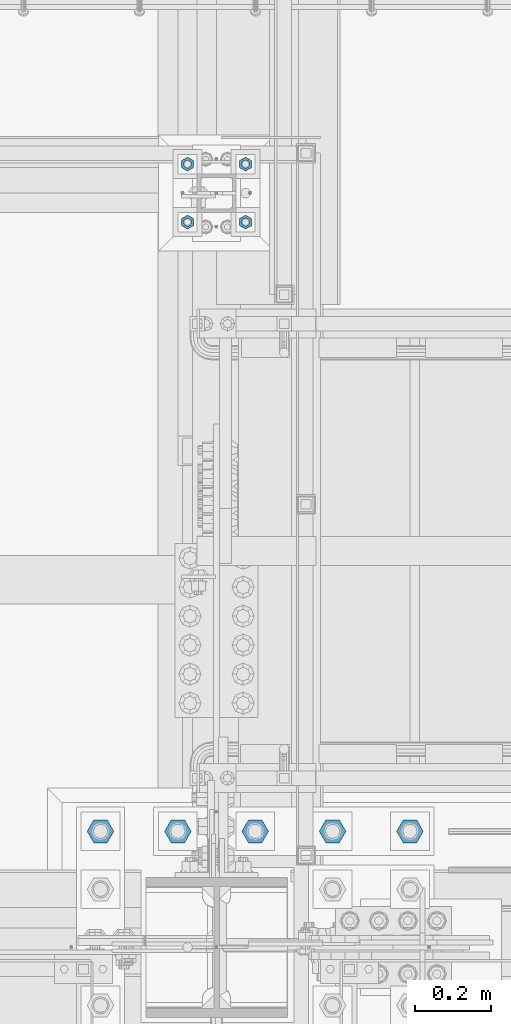
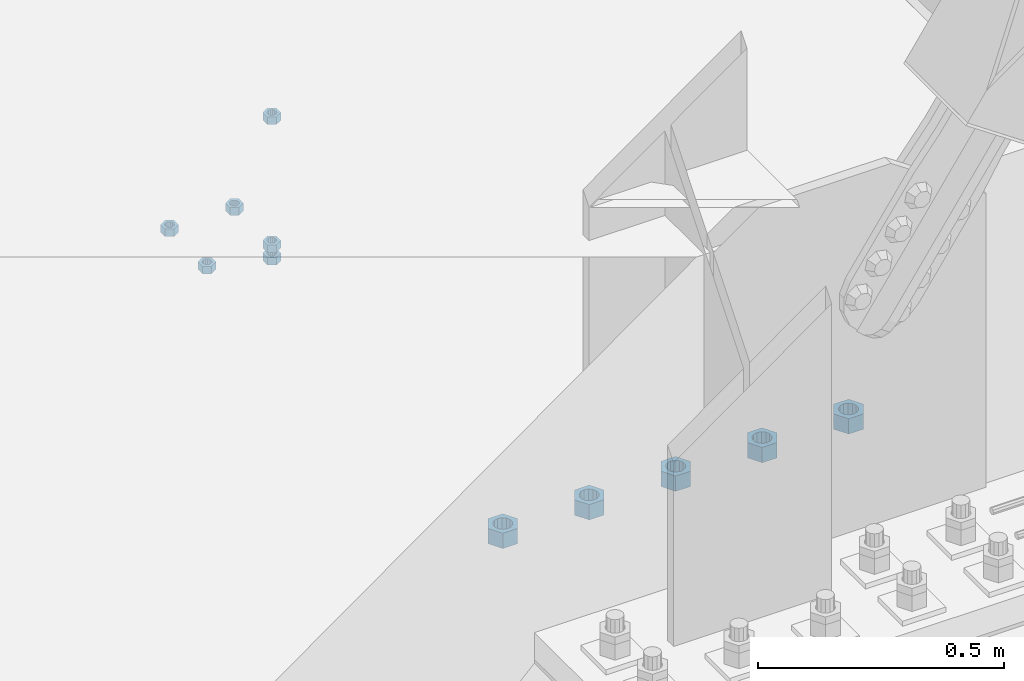
# One storey, part 1666 of 3843: 11 columns, 2 elements without a shape of their own.
"""IFC2X3 building model written with IfcOpenShell, lengths in millimetres."""

from ifc_helpers import new_model, si_unit, frame, origin_with_axes, place, context, subcontext, project, spatial, faceted_brep, material, type_object, element, aggregate, save


model = new_model("IFC2X3")

# Units and contexts
model_context = context("Model", 3, precision=1e-05, world=origin_with_axes())
body_context = subcontext(model_context, "Body", "Model", "MODEL_VIEW")
ifc_project = project(units=[si_unit("LENGTHUNIT", "METRE", prefix="MILLI"), si_unit("AREAUNIT", "SQUARE_METRE"), si_unit("VOLUMEUNIT", "CUBIC_METRE"), si_unit("MASSUNIT", "GRAM", prefix="KILO"), si_unit("TIMEUNIT", "SECOND"), si_unit("PLANEANGLEUNIT", "RADIAN"), si_unit("SOLIDANGLEUNIT", "STERADIAN"), si_unit("THERMODYNAMICTEMPERATUREUNIT", "DEGREE_CELSIUS"), si_unit("LUMINOUSINTENSITYUNIT", "LUMEN")], contexts=[model_context])

# Site, building, storey
site_placement = place(None, origin_with_axes())
site = spatial("IfcSite", under=ifc_project, at=site_placement, CompositionType="ELEMENT")
building_placement = place(site_placement, origin_with_axes())
building = spatial("IfcBuilding", under=site, at=building_placement, Name="Undefined", CompositionType="ELEMENT")
storey_placement = place(building_placement, origin_with_axes())
storey = spatial("IfcBuildingStorey", under=building, at=storey_placement, Name="Undefined", CompositionType="ELEMENT", Elevation=0.0)

# Assembly, columns
assembly_1_placement = place(storey_placement, origin_with_axes())
assembly_1 = element("IfcElementAssembly", 1, at=assembly_1_placement, inside=storey, Name="TEMPLATE", AssemblyPlace="NOTDEFINED", PredefinedType="RIGID_FRAME")
ifc_material_1 = material(Name="STEEL/A36")
column_type_1 = type_object("IfcColumnType", Name="3/4_HEAVY_HEX_NUT", PredefinedType="NOTDEFINED")
column_1_placement = place(assembly_1_placement, frame((56007.0, 27520.9, 29330.65), z_axis=(1.0, 0.0, 0.0), x_axis=(0.0, 0.0, -1.0)))
column_1 = element("IfcColumn", 2, at=column_1_placement, type_object=column_type_1, material=ifc_material_1, Name="NUT", ObjectType="3/4_HEAVY_HEX_NUT", context=body_context, shape_type="Brep", body=[
    faceted_brep([(0.0, -18.2600002288818, 0.0), (0.0, -9.13000011444092, -15.8100004196167), (19.0500000000029, -9.13000011444092, -15.8100004196167), (19.0500000000029, -18.2600002288818, 0.0), (0.0, 9.13000011444092, -15.8100004196167), (19.0500000000029, 9.13000011444092, -15.8100004196167), (0.0, 18.2600002288818, 0.0), (19.0500000000029, 18.2600002288818, 0.0), (0.0, 9.13000011444092, 15.8100004196167), (19.0500000000029, 9.13000011444092, 15.8100004196167), (0.0, -9.13000011444092, 15.8100004196167), (19.0500000000029, -9.13000011444092, 15.8100004196167), (0.0, 0.0, 10.3199996948242), (0.0, 4.47768005527905, 9.29799844179797), (19.0500000000029, 4.47768005527905, 9.29799844179797), (19.0500000000029, 0.0, 10.3199996948242), (0.0, 8.06850066047627, 6.43441456490837), (19.0500000000029, 8.06850066047627, 6.43441456490837), (0.0, 10.0612557561908, 2.2964159705225), (19.0500000000029, 10.0612557561908, 2.2964159705225), (0.0, 10.0612557561908, -2.2964159705225), (19.0500000000029, 10.0612557561908, -2.2964159705225), (0.0, 8.06850066047627, -6.43441456490837), (19.0500000000029, 8.06850066047627, -6.43441456490837), (0.0, 4.47768005527905, -9.29799844179797), (19.0500000000029, 4.47768005527905, -9.29799844179797), (0.0, 0.0, -10.3199996948242), (19.0500000000029, 0.0, -10.3199996948242), (0.0, -4.47768005527905, -9.29799844179797), (19.0500000000029, -4.47768005527905, -9.29799844179797), (0.0, -8.06850066047627, -6.43441456490837), (19.0500000000029, -8.06850066047627, -6.43441456490837), (0.0, -10.0612557561908, -2.2964159705225), (19.0500000000029, -10.0612557561908, -2.2964159705225), (0.0, -10.0612557561908, 2.2964159705225), (19.0500000000029, -10.0612557561908, 2.2964159705225), (0.0, -8.06850066047627, 6.43441456490837), (19.0500000000029, -8.06850066047627, 6.43441456490837), (0.0, -4.47768005527905, 9.29799844179797), (19.0500000000029, -4.47768005527905, 9.29799844179797)], [[[0, 1, 2, 3]], [[1, 4, 5, 2]], [[4, 6, 7, 5]], [[6, 8, 9, 7]], [[8, 10, 11, 9]], [[10, 0, 3, 11]], [[12, 13, 14, 15]], [[13, 16, 17, 14]], [[16, 18, 19, 17]], [[18, 20, 21, 19]], [[20, 22, 23, 21]], [[22, 24, 25, 23]], [[24, 26, 27, 25]], [[26, 28, 29, 27]], [[28, 30, 31, 29]], [[30, 32, 33, 31]], [[32, 34, 35, 33]], [[34, 36, 37, 35]], [[36, 38, 39, 37]], [[38, 12, 15, 39]], [[5, 7, 9, 11, 3, 2], [17, 19, 21, 23, 25, 27, 29, 31, 33, 35, 37, 39, 15, 14]], [[10, 8, 6, 4, 1, 0], [38, 36, 34, 32, 30, 28, 26, 24, 22, 20, 18, 16, 13, 12]]]),
])
column_2_placement = place(assembly_1_placement, frame((56007.0, 27673.3, 29330.65), z_axis=(-1.0, 0.0, 0.0), x_axis=(0.0, 0.0, -1.0)))
column_2 = element("IfcColumn", 3, at=column_2_placement, type_object=column_type_1, material=ifc_material_1, Name="NUT", ObjectType="3/4_HEAVY_HEX_NUT", context=body_context, shape_type="Brep", body=[
    faceted_brep([(0.0, -18.2600002288818, 0.0), (0.0, -9.13000011444092, -15.8100004196167), (19.0500000000029, -9.13000011444092, -15.8100004196167), (19.0500000000029, -18.2600002288818, 0.0), (0.0, 9.13000011444092, -15.8100004196167), (19.0500000000029, 9.13000011444092, -15.8100004196167), (0.0, 18.2600002288818, 0.0), (19.0500000000029, 18.2600002288818, 0.0), (0.0, 9.13000011444092, 15.8100004196167), (19.0500000000029, 9.13000011444092, 15.8100004196167), (0.0, -9.13000011444092, 15.8100004196167), (19.0500000000029, -9.13000011444092, 15.8100004196167), (0.0, 0.0, 10.3199996948242), (0.0, 4.47768005527905, 9.29799844179797), (19.0500000000029, 4.47768005527905, 9.29799844179797), (19.0500000000029, 0.0, 10.3199996948242), (0.0, 8.06850066047627, 6.43441456490837), (19.0500000000029, 8.06850066047627, 6.43441456490837), (0.0, 10.0612557561908, 2.2964159705225), (19.0500000000029, 10.0612557561908, 2.2964159705225), (0.0, 10.0612557561908, -2.2964159705225), (19.0500000000029, 10.0612557561908, -2.2964159705225), (0.0, 8.06850066047627, -6.43441456490837), (19.0500000000029, 8.06850066047627, -6.43441456490837), (0.0, 4.47768005527905, -9.29799844179797), (19.0500000000029, 4.47768005527905, -9.29799844179797), (0.0, 0.0, -10.3199996948242), (19.0500000000029, 0.0, -10.3199996948242), (0.0, -4.47768005527905, -9.29799844179797), (19.0500000000029, -4.47768005527905, -9.29799844179797), (0.0, -8.06850066047627, -6.43441456490837), (19.0500000000029, -8.06850066047627, -6.43441456490837), (0.0, -10.0612557561908, -2.2964159705225), (19.0500000000029, -10.0612557561908, -2.2964159705225), (0.0, -10.0612557561908, 2.2964159705225), (19.0500000000029, -10.0612557561908, 2.2964159705225), (0.0, -8.06850066047627, 6.43441456490837), (19.0500000000029, -8.06850066047627, 6.43441456490837), (0.0, -4.47768005527905, 9.29799844179797), (19.0500000000029, -4.47768005527905, 9.29799844179797)], [[[0, 1, 2, 3]], [[1, 4, 5, 2]], [[4, 6, 7, 5]], [[6, 8, 9, 7]], [[8, 10, 11, 9]], [[10, 0, 3, 11]], [[12, 13, 14, 15]], [[13, 16, 17, 14]], [[16, 18, 19, 17]], [[18, 20, 21, 19]], [[20, 22, 23, 21]], [[22, 24, 25, 23]], [[24, 26, 27, 25]], [[26, 28, 29, 27]], [[28, 30, 31, 29]], [[30, 32, 33, 31]], [[32, 34, 35, 33]], [[34, 36, 37, 35]], [[36, 38, 39, 37]], [[38, 12, 15, 39]], [[5, 7, 9, 11, 3, 2], [17, 19, 21, 23, 25, 27, 29, 31, 33, 35, 37, 39, 15, 14]], [[10, 8, 6, 4, 1, 0], [38, 36, 34, 32, 30, 28, 26, 24, 22, 20, 18, 16, 13, 12]]]),
])
column_3_placement = place(assembly_1_placement, frame((55854.6, 27520.9, 29330.65), z_axis=(1.0, 0.0, 0.0), x_axis=(0.0, 0.0, -1.0)))
column_3 = element("IfcColumn", 4, at=column_3_placement, type_object=column_type_1, material=ifc_material_1, Name="NUT", ObjectType="3/4_HEAVY_HEX_NUT", context=body_context, shape_type="Brep", body=[
    faceted_brep([(0.0, -18.2600002288818, 0.0), (0.0, -9.13000011444092, -15.8100004196167), (19.0500000000029, -9.13000011444092, -15.8100004196167), (19.0500000000029, -18.2600002288818, 0.0), (0.0, 9.13000011444092, -15.8100004196167), (19.0500000000029, 9.13000011444092, -15.8100004196167), (0.0, 18.2600002288818, 0.0), (19.0500000000029, 18.2600002288818, 0.0), (0.0, 9.13000011444092, 15.8100004196167), (19.0500000000029, 9.13000011444092, 15.8100004196167), (0.0, -9.13000011444092, 15.8100004196167), (19.0500000000029, -9.13000011444092, 15.8100004196167), (0.0, 0.0, 10.3199996948242), (0.0, 4.47768005527905, 9.29799844179797), (19.0500000000029, 4.47768005527905, 9.29799844179797), (19.0500000000029, 0.0, 10.3199996948242), (0.0, 8.06850066047627, 6.43441456490837), (19.0500000000029, 8.06850066047627, 6.43441456490837), (0.0, 10.0612557561908, 2.2964159705225), (19.0500000000029, 10.0612557561908, 2.2964159705225), (0.0, 10.0612557561908, -2.2964159705225), (19.0500000000029, 10.0612557561908, -2.2964159705225), (0.0, 8.06850066047627, -6.43441456490837), (19.0500000000029, 8.06850066047627, -6.43441456490837), (0.0, 4.47768005527905, -9.29799844179797), (19.0500000000029, 4.47768005527905, -9.29799844179797), (0.0, 0.0, -10.3199996948242), (19.0500000000029, 0.0, -10.3199996948242), (0.0, -4.47768005527905, -9.29799844179797), (19.0500000000029, -4.47768005527905, -9.29799844179797), (0.0, -8.06850066047627, -6.43441456490837), (19.0500000000029, -8.06850066047627, -6.43441456490837), (0.0, -10.0612557561908, -2.2964159705225), (19.0500000000029, -10.0612557561908, -2.2964159705225), (0.0, -10.0612557561908, 2.2964159705225), (19.0500000000029, -10.0612557561908, 2.2964159705225), (0.0, -8.06850066047627, 6.43441456490837), (19.0500000000029, -8.06850066047627, 6.43441456490837), (0.0, -4.47768005527905, 9.29799844179797), (19.0500000000029, -4.47768005527905, 9.29799844179797)], [[[0, 1, 2, 3]], [[1, 4, 5, 2]], [[4, 6, 7, 5]], [[6, 8, 9, 7]], [[8, 10, 11, 9]], [[10, 0, 3, 11]], [[12, 13, 14, 15]], [[13, 16, 17, 14]], [[16, 18, 19, 17]], [[18, 20, 21, 19]], [[20, 22, 23, 21]], [[22, 24, 25, 23]], [[24, 26, 27, 25]], [[26, 28, 29, 27]], [[28, 30, 31, 29]], [[30, 32, 33, 31]], [[32, 34, 35, 33]], [[34, 36, 37, 35]], [[36, 38, 39, 37]], [[38, 12, 15, 39]], [[5, 7, 9, 11, 3, 2], [17, 19, 21, 23, 25, 27, 29, 31, 33, 35, 37, 39, 15, 14]], [[10, 8, 6, 4, 1, 0], [38, 36, 34, 32, 30, 28, 26, 24, 22, 20, 18, 16, 13, 12]]]),
])
column_4_placement = place(assembly_1_placement, frame((55854.6, 27673.3, 29330.65), z_axis=(-1.0, 0.0, 0.0), x_axis=(0.0, 0.0, -1.0)))
column_4 = element("IfcColumn", 5, at=column_4_placement, type_object=column_type_1, material=ifc_material_1, Name="NUT", ObjectType="3/4_HEAVY_HEX_NUT", context=body_context, shape_type="Brep", body=[
    faceted_brep([(0.0, -18.2600002288818, 0.0), (0.0, -9.13000011444092, -15.8100004196167), (19.0500000000029, -9.13000011444092, -15.8100004196167), (19.0500000000029, -18.2600002288818, 0.0), (0.0, 9.13000011444092, -15.8100004196167), (19.0500000000029, 9.13000011444092, -15.8100004196167), (0.0, 18.2600002288818, 0.0), (19.0500000000029, 18.2600002288818, 0.0), (0.0, 9.13000011444092, 15.8100004196167), (19.0500000000029, 9.13000011444092, 15.8100004196167), (0.0, -9.13000011444092, 15.8100004196167), (19.0500000000029, -9.13000011444092, 15.8100004196167), (0.0, 0.0, 10.3199996948242), (0.0, 4.47768005527905, 9.29799844179797), (19.0500000000029, 4.47768005527905, 9.29799844179797), (19.0500000000029, 0.0, 10.3199996948242), (0.0, 8.06850066047627, 6.43441456490837), (19.0500000000029, 8.06850066047627, 6.43441456490837), (0.0, 10.0612557561908, 2.2964159705225), (19.0500000000029, 10.0612557561908, 2.2964159705225), (0.0, 10.0612557561908, -2.2964159705225), (19.0500000000029, 10.0612557561908, -2.2964159705225), (0.0, 8.06850066047627, -6.43441456490837), (19.0500000000029, 8.06850066047627, -6.43441456490837), (0.0, 4.47768005527905, -9.29799844179797), (19.0500000000029, 4.47768005527905, -9.29799844179797), (0.0, 0.0, -10.3199996948242), (19.0500000000029, 0.0, -10.3199996948242), (0.0, -4.47768005527905, -9.29799844179797), (19.0500000000029, -4.47768005527905, -9.29799844179797), (0.0, -8.06850066047627, -6.43441456490837), (19.0500000000029, -8.06850066047627, -6.43441456490837), (0.0, -10.0612557561908, -2.2964159705225), (19.0500000000029, -10.0612557561908, -2.2964159705225), (0.0, -10.0612557561908, 2.2964159705225), (19.0500000000029, -10.0612557561908, 2.2964159705225), (0.0, -8.06850066047627, 6.43441456490837), (19.0500000000029, -8.06850066047627, 6.43441456490837), (0.0, -4.47768005527905, 9.29799844179797), (19.0500000000029, -4.47768005527905, 9.29799844179797)], [[[0, 1, 2, 3]], [[1, 4, 5, 2]], [[4, 6, 7, 5]], [[6, 8, 9, 7]], [[8, 10, 11, 9]], [[10, 0, 3, 11]], [[12, 13, 14, 15]], [[13, 16, 17, 14]], [[16, 18, 19, 17]], [[18, 20, 21, 19]], [[20, 22, 23, 21]], [[22, 24, 25, 23]], [[24, 26, 27, 25]], [[26, 28, 29, 27]], [[28, 30, 31, 29]], [[30, 32, 33, 31]], [[32, 34, 35, 33]], [[34, 36, 37, 35]], [[36, 38, 39, 37]], [[38, 12, 15, 39]], [[5, 7, 9, 11, 3, 2], [17, 19, 21, 23, 25, 27, 29, 31, 33, 35, 37, 39, 15, 14]], [[10, 8, 6, 4, 1, 0], [38, 36, 34, 32, 30, 28, 26, 24, 22, 20, 18, 16, 13, 12]]]),
])
column_5_placement = place(assembly_1_placement, frame((56007.0, 27520.9, 29648.15), z_axis=(1.0, 0.0, 0.0), x_axis=(0.0, 0.0, -1.0)))
column_5 = element("IfcColumn", 6, at=column_5_placement, type_object=column_type_1, material=ifc_material_1, Name="NUT", ObjectType="3/4_HEAVY_HEX_NUT", context=body_context, shape_type="Brep", body=[
    faceted_brep([(0.0, -18.2600002288818, 0.0), (0.0, -9.13000011444092, -15.8100004196167), (19.0500000000029, -9.13000011444092, -15.8100004196167), (19.0500000000029, -18.2600002288818, 0.0), (0.0, 9.13000011444092, -15.8100004196167), (19.0500000000029, 9.13000011444092, -15.8100004196167), (0.0, 18.2600002288818, 0.0), (19.0500000000029, 18.2600002288818, 0.0), (0.0, 9.13000011444092, 15.8100004196167), (19.0500000000029, 9.13000011444092, 15.8100004196167), (0.0, -9.13000011444092, 15.8100004196167), (19.0500000000029, -9.13000011444092, 15.8100004196167), (0.0, 0.0, 10.3199996948242), (0.0, 4.47768005527905, 9.29799844179797), (19.0500000000029, 4.47768005527905, 9.29799844179797), (19.0500000000029, 0.0, 10.3199996948242), (0.0, 8.06850066047627, 6.43441456490837), (19.0500000000029, 8.06850066047627, 6.43441456490837), (0.0, 10.0612557561908, 2.2964159705225), (19.0500000000029, 10.0612557561908, 2.2964159705225), (0.0, 10.0612557561908, -2.2964159705225), (19.0500000000029, 10.0612557561908, -2.2964159705225), (0.0, 8.06850066047627, -6.43441456490837), (19.0500000000029, 8.06850066047627, -6.43441456490837), (0.0, 4.47768005527905, -9.29799844179797), (19.0500000000029, 4.47768005527905, -9.29799844179797), (0.0, 0.0, -10.3199996948242), (19.0500000000029, 0.0, -10.3199996948242), (0.0, -4.47768005527905, -9.29799844179797), (19.0500000000029, -4.47768005527905, -9.29799844179797), (0.0, -8.06850066047627, -6.43441456490837), (19.0500000000029, -8.06850066047627, -6.43441456490837), (0.0, -10.0612557561908, -2.2964159705225), (19.0500000000029, -10.0612557561908, -2.2964159705225), (0.0, -10.0612557561908, 2.2964159705225), (19.0500000000029, -10.0612557561908, 2.2964159705225), (0.0, -8.06850066047627, 6.43441456490837), (19.0500000000029, -8.06850066047627, 6.43441456490837), (0.0, -4.47768005527905, 9.29799844179797), (19.0500000000029, -4.47768005527905, 9.29799844179797)], [[[0, 1, 2, 3]], [[1, 4, 5, 2]], [[4, 6, 7, 5]], [[6, 8, 9, 7]], [[8, 10, 11, 9]], [[10, 0, 3, 11]], [[12, 13, 14, 15]], [[13, 16, 17, 14]], [[16, 18, 19, 17]], [[18, 20, 21, 19]], [[20, 22, 23, 21]], [[22, 24, 25, 23]], [[24, 26, 27, 25]], [[26, 28, 29, 27]], [[28, 30, 31, 29]], [[30, 32, 33, 31]], [[32, 34, 35, 33]], [[34, 36, 37, 35]], [[36, 38, 39, 37]], [[38, 12, 15, 39]], [[5, 7, 9, 11, 3, 2], [17, 19, 21, 23, 25, 27, 29, 31, 33, 35, 37, 39, 15, 14]], [[10, 8, 6, 4, 1, 0], [38, 36, 34, 32, 30, 28, 26, 24, 22, 20, 18, 16, 13, 12]]]),
])
column_6_placement = place(assembly_1_placement, frame((56007.0, 27520.9, 29298.9), z_axis=(1.0, 0.0, 0.0), x_axis=(0.0, 0.0, -1.0)))
column_6 = element("IfcColumn", 7, at=column_6_placement, type_object=column_type_1, material=ifc_material_1, Name="NUT", ObjectType="3/4_HEAVY_HEX_NUT", context=body_context, shape_type="Brep", body=[
    faceted_brep([(0.0, -18.2600002288818, 0.0), (0.0, -9.13000011444092, -15.8100004196167), (19.0500000000029, -9.13000011444092, -15.8100004196167), (19.0500000000029, -18.2600002288818, 0.0), (0.0, 9.13000011444092, -15.8100004196167), (19.0500000000029, 9.13000011444092, -15.8100004196167), (0.0, 18.2600002288818, 0.0), (19.0500000000029, 18.2600002288818, 0.0), (0.0, 9.13000011444092, 15.8100004196167), (19.0500000000029, 9.13000011444092, 15.8100004196167), (0.0, -9.13000011444092, 15.8100004196167), (19.0500000000029, -9.13000011444092, 15.8100004196167), (0.0, 0.0, 10.3199996948242), (0.0, 4.47768005527905, 9.29799844179797), (19.0500000000029, 4.47768005527905, 9.29799844179797), (19.0500000000029, 0.0, 10.3199996948242), (0.0, 8.06850066047627, 6.43441456490837), (19.0500000000029, 8.06850066047627, 6.43441456490837), (0.0, 10.0612557561908, 2.2964159705225), (19.0500000000029, 10.0612557561908, 2.2964159705225), (0.0, 10.0612557561908, -2.2964159705225), (19.0500000000029, 10.0612557561908, -2.2964159705225), (0.0, 8.06850066047627, -6.43441456490837), (19.0500000000029, 8.06850066047627, -6.43441456490837), (0.0, 4.47768005527905, -9.29799844179797), (19.0500000000029, 4.47768005527905, -9.29799844179797), (0.0, 0.0, -10.3199996948242), (19.0500000000029, 0.0, -10.3199996948242), (0.0, -4.47768005527905, -9.29799844179797), (19.0500000000029, -4.47768005527905, -9.29799844179797), (0.0, -8.06850066047627, -6.43441456490837), (19.0500000000029, -8.06850066047627, -6.43441456490837), (0.0, -10.0612557561908, -2.2964159705225), (19.0500000000029, -10.0612557561908, -2.2964159705225), (0.0, -10.0612557561908, 2.2964159705225), (19.0500000000029, -10.0612557561908, 2.2964159705225), (0.0, -8.06850066047627, 6.43441456490837), (19.0500000000029, -8.06850066047627, 6.43441456490837), (0.0, -4.47768005527905, 9.29799844179797), (19.0500000000029, -4.47768005527905, 9.29799844179797)], [[[0, 1, 2, 3]], [[1, 4, 5, 2]], [[4, 6, 7, 5]], [[6, 8, 9, 7]], [[8, 10, 11, 9]], [[10, 0, 3, 11]], [[12, 13, 14, 15]], [[13, 16, 17, 14]], [[16, 18, 19, 17]], [[18, 20, 21, 19]], [[20, 22, 23, 21]], [[22, 24, 25, 23]], [[24, 26, 27, 25]], [[26, 28, 29, 27]], [[28, 30, 31, 29]], [[30, 32, 33, 31]], [[32, 34, 35, 33]], [[34, 36, 37, 35]], [[36, 38, 39, 37]], [[38, 12, 15, 39]], [[5, 7, 9, 11, 3, 2], [17, 19, 21, 23, 25, 27, 29, 31, 33, 35, 37, 39, 15, 14]], [[10, 8, 6, 4, 1, 0], [38, 36, 34, 32, 30, 28, 26, 24, 22, 20, 18, 16, 13, 12]]]),
])
aggregate(assembly_1, [column_1, column_2, column_3, column_4, column_5, column_6])

assembly_2_placement = place(storey_placement, origin_with_axes())
assembly_2 = element("IfcElementAssembly", 8, at=assembly_2_placement, inside=storey, Name="TEMPLATE", AssemblyPlace="NOTDEFINED", PredefinedType="RIGID_FRAME")
ifc_material_2 = material(Name="STEEL/A572-50")
column_type_2 = type_object("IfcColumnType", Name="1-1/2_HEAVY_HEX_NUT", PredefinedType="NOTDEFINED")
column_7_placement = place(assembly_2_placement, frame((55626.0, 25920.7, 29730.7), z_axis=(0.0, -1.0, 0.0), x_axis=(0.0, 0.0, -1.0)))
column_7 = element("IfcColumn", 9, at=column_7_placement, type_object=column_type_2, material=ifc_material_2, Name="NUT", ObjectType="1-1/2_HEAVY_HEX_NUT", context=body_context, shape_type="Brep", body=[
    faceted_brep([(0.0, -34.9199981689453, 0.0), (0.0, -17.4599990844727, -30.25), (38.0999999999985, -17.4599990844727, -30.25), (38.0999999999985, -34.9199981689453, 0.0), (0.0, 17.4599990844727, -30.25), (38.0999999999985, 17.4599990844727, -30.25), (0.0, 34.9199981689453, 0.0), (38.0999999999985, 34.9199981689453, 0.0), (0.0, 17.4599990844727, 30.25), (38.0999999999985, 17.4599990844727, 30.25), (0.0, -17.4599990844727, 30.25), (38.0999999999985, -17.4599990844727, 30.25), (0.0, 0.0, 20.6399993896484), (0.0, 8.9553601105581, 18.5959968835959), (38.0999999999985, 8.9553601105581, 18.5959968835959), (38.0999999999985, 0.0, 20.6399993896484), (0.0, 16.1370013209525, 12.8688291298167), (38.0999999999985, 16.1370013209525, 12.8688291298167), (0.0, 20.1225115123816, 4.59283194104501), (38.0999999999985, 20.1225115123816, 4.59283194104501), (0.0, 20.1225115123816, -4.59283194104501), (38.0999999999985, 20.1225115123816, -4.59283194104501), (0.0, 16.1370013209525, -12.8688291298167), (38.0999999999985, 16.1370013209525, -12.8688291298167), (0.0, 8.9553601105581, -18.5959968835959), (38.0999999999985, 8.9553601105581, -18.5959968835959), (0.0, 0.0, -20.6399993896484), (38.0999999999985, 0.0, -20.6399993896484), (0.0, -8.9553601105581, -18.5959968835959), (38.0999999999985, -8.9553601105581, -18.5959968835959), (0.0, -16.1370013209525, -12.8688291298167), (38.0999999999985, -16.1370013209525, -12.8688291298167), (0.0, -20.1225115123816, -4.59283194104501), (38.0999999999985, -20.1225115123816, -4.59283194104501), (0.0, -20.1225115123816, 4.59283194104501), (38.0999999999985, -20.1225115123816, 4.59283194104501), (0.0, -16.1370013209525, 12.8688291298167), (38.0999999999985, -16.1370013209525, 12.8688291298167), (0.0, -8.9553601105581, 18.5959968835959), (38.0999999999985, -8.9553601105581, 18.5959968835959)], [[[0, 1, 2, 3]], [[1, 4, 5, 2]], [[4, 6, 7, 5]], [[6, 8, 9, 7]], [[8, 10, 11, 9]], [[10, 0, 3, 11]], [[12, 13, 14, 15]], [[13, 16, 17, 14]], [[16, 18, 19, 17]], [[18, 20, 21, 19]], [[20, 22, 23, 21]], [[22, 24, 25, 23]], [[24, 26, 27, 25]], [[26, 28, 29, 27]], [[28, 30, 31, 29]], [[30, 32, 33, 31]], [[32, 34, 35, 33]], [[34, 36, 37, 35]], [[36, 38, 39, 37]], [[38, 12, 15, 39]], [[5, 7, 9, 11, 3, 2], [17, 19, 21, 23, 25, 27, 29, 31, 33, 35, 37, 39, 15, 14]], [[10, 8, 6, 4, 1, 0], [38, 36, 34, 32, 30, 28, 26, 24, 22, 20, 18, 16, 13, 12]]]),
])
column_8_placement = place(assembly_2_placement, frame((55829.2, 25920.7, 29730.7), z_axis=(0.0, -1.0, 0.0), x_axis=(0.0, 0.0, -1.0)))
column_8 = element("IfcColumn", 10, at=column_8_placement, type_object=column_type_2, material=ifc_material_2, Name="NUT", ObjectType="1-1/2_HEAVY_HEX_NUT", context=body_context, shape_type="Brep", body=[
    faceted_brep([(0.0, -34.9199981689453, 0.0), (0.0, -17.4599990844727, -30.25), (38.0999999999985, -17.4599990844727, -30.25), (38.0999999999985, -34.9199981689453, 0.0), (0.0, 17.4599990844727, -30.25), (38.0999999999985, 17.4599990844727, -30.25), (0.0, 34.9199981689453, 0.0), (38.0999999999985, 34.9199981689453, 0.0), (0.0, 17.4599990844727, 30.25), (38.0999999999985, 17.4599990844727, 30.25), (0.0, -17.4599990844727, 30.25), (38.0999999999985, -17.4599990844727, 30.25), (0.0, 0.0, 20.6399993896484), (0.0, 8.9553601105581, 18.5959968835959), (38.0999999999985, 8.9553601105581, 18.5959968835959), (38.0999999999985, 0.0, 20.6399993896484), (0.0, 16.1370013209525, 12.8688291298167), (38.0999999999985, 16.1370013209525, 12.8688291298167), (0.0, 20.1225115123816, 4.59283194104501), (38.0999999999985, 20.1225115123816, 4.59283194104501), (0.0, 20.1225115123816, -4.59283194104501), (38.0999999999985, 20.1225115123816, -4.59283194104501), (0.0, 16.1370013209525, -12.8688291298167), (38.0999999999985, 16.1370013209525, -12.8688291298167), (0.0, 8.9553601105581, -18.5959968835959), (38.0999999999985, 8.9553601105581, -18.5959968835959), (0.0, 0.0, -20.6399993896484), (38.0999999999985, 0.0, -20.6399993896484), (0.0, -8.9553601105581, -18.5959968835959), (38.0999999999985, -8.9553601105581, -18.5959968835959), (0.0, -16.1370013209525, -12.8688291298167), (38.0999999999985, -16.1370013209525, -12.8688291298167), (0.0, -20.1225115123816, -4.59283194104501), (38.0999999999985, -20.1225115123816, -4.59283194104501), (0.0, -20.1225115123816, 4.59283194104501), (38.0999999999985, -20.1225115123816, 4.59283194104501), (0.0, -16.1370013209525, 12.8688291298167), (38.0999999999985, -16.1370013209525, 12.8688291298167), (0.0, -8.9553601105581, 18.5959968835959), (38.0999999999985, -8.9553601105581, 18.5959968835959)], [[[0, 1, 2, 3]], [[1, 4, 5, 2]], [[4, 6, 7, 5]], [[6, 8, 9, 7]], [[8, 10, 11, 9]], [[10, 0, 3, 11]], [[12, 13, 14, 15]], [[13, 16, 17, 14]], [[16, 18, 19, 17]], [[18, 20, 21, 19]], [[20, 22, 23, 21]], [[22, 24, 25, 23]], [[24, 26, 27, 25]], [[26, 28, 29, 27]], [[28, 30, 31, 29]], [[30, 32, 33, 31]], [[32, 34, 35, 33]], [[34, 36, 37, 35]], [[36, 38, 39, 37]], [[38, 12, 15, 39]], [[5, 7, 9, 11, 3, 2], [17, 19, 21, 23, 25, 27, 29, 31, 33, 35, 37, 39, 15, 14]], [[10, 8, 6, 4, 1, 0], [38, 36, 34, 32, 30, 28, 26, 24, 22, 20, 18, 16, 13, 12]]]),
])
column_9_placement = place(assembly_2_placement, frame((56032.4, 25920.7, 29730.7), z_axis=(0.0, -1.0, 0.0), x_axis=(0.0, 0.0, -1.0)))
column_9 = element("IfcColumn", 11, at=column_9_placement, type_object=column_type_2, material=ifc_material_2, Name="NUT", ObjectType="1-1/2_HEAVY_HEX_NUT", context=body_context, shape_type="Brep", body=[
    faceted_brep([(0.0, -34.9199981689453, 0.0), (0.0, -17.4599990844727, -30.25), (38.0999999999985, -17.4599990844727, -30.25), (38.0999999999985, -34.9199981689453, 0.0), (0.0, 17.4599990844727, -30.25), (38.0999999999985, 17.4599990844727, -30.25), (0.0, 34.9199981689453, 0.0), (38.0999999999985, 34.9199981689453, 0.0), (0.0, 17.4599990844727, 30.25), (38.0999999999985, 17.4599990844727, 30.25), (0.0, -17.4599990844727, 30.25), (38.0999999999985, -17.4599990844727, 30.25), (0.0, 0.0, 20.6399993896484), (0.0, 8.9553601105581, 18.5959968835959), (38.0999999999985, 8.9553601105581, 18.5959968835959), (38.0999999999985, 0.0, 20.6399993896484), (0.0, 16.1370013209525, 12.8688291298167), (38.0999999999985, 16.1370013209525, 12.8688291298167), (0.0, 20.1225115123816, 4.59283194104501), (38.0999999999985, 20.1225115123816, 4.59283194104501), (0.0, 20.1225115123816, -4.59283194104501), (38.0999999999985, 20.1225115123816, -4.59283194104501), (0.0, 16.1370013209525, -12.8688291298167), (38.0999999999985, 16.1370013209525, -12.8688291298167), (0.0, 8.9553601105581, -18.5959968835959), (38.0999999999985, 8.9553601105581, -18.5959968835959), (0.0, 0.0, -20.6399993896484), (38.0999999999985, 0.0, -20.6399993896484), (0.0, -8.9553601105581, -18.5959968835959), (38.0999999999985, -8.9553601105581, -18.5959968835959), (0.0, -16.1370013209525, -12.8688291298167), (38.0999999999985, -16.1370013209525, -12.8688291298167), (0.0, -20.1225115123816, -4.59283194104501), (38.0999999999985, -20.1225115123816, -4.59283194104501), (0.0, -20.1225115123816, 4.59283194104501), (38.0999999999985, -20.1225115123816, 4.59283194104501), (0.0, -16.1370013209525, 12.8688291298167), (38.0999999999985, -16.1370013209525, 12.8688291298167), (0.0, -8.9553601105581, 18.5959968835959), (38.0999999999985, -8.9553601105581, 18.5959968835959)], [[[0, 1, 2, 3]], [[1, 4, 5, 2]], [[4, 6, 7, 5]], [[6, 8, 9, 7]], [[8, 10, 11, 9]], [[10, 0, 3, 11]], [[12, 13, 14, 15]], [[13, 16, 17, 14]], [[16, 18, 19, 17]], [[18, 20, 21, 19]], [[20, 22, 23, 21]], [[22, 24, 25, 23]], [[24, 26, 27, 25]], [[26, 28, 29, 27]], [[28, 30, 31, 29]], [[30, 32, 33, 31]], [[32, 34, 35, 33]], [[34, 36, 37, 35]], [[36, 38, 39, 37]], [[38, 12, 15, 39]], [[5, 7, 9, 11, 3, 2], [17, 19, 21, 23, 25, 27, 29, 31, 33, 35, 37, 39, 15, 14]], [[10, 8, 6, 4, 1, 0], [38, 36, 34, 32, 30, 28, 26, 24, 22, 20, 18, 16, 13, 12]]]),
])
column_10_placement = place(assembly_2_placement, frame((56235.6, 25920.7, 29730.7), z_axis=(0.0, 1.0, 0.0), x_axis=(0.0, 0.0, -1.0)))
column_10 = element("IfcColumn", 12, at=column_10_placement, type_object=column_type_2, material=ifc_material_2, Name="NUT", ObjectType="1-1/2_HEAVY_HEX_NUT", context=body_context, shape_type="Brep", body=[
    faceted_brep([(0.0, -34.9199981689453, 0.0), (0.0, -17.4599990844727, -30.25), (38.0999999999985, -17.4599990844727, -30.25), (38.0999999999985, -34.9199981689453, 0.0), (0.0, 17.4599990844727, -30.25), (38.0999999999985, 17.4599990844727, -30.25), (0.0, 34.9199981689453, 0.0), (38.0999999999985, 34.9199981689453, 0.0), (0.0, 17.4599990844727, 30.25), (38.0999999999985, 17.4599990844727, 30.25), (0.0, -17.4599990844727, 30.25), (38.0999999999985, -17.4599990844727, 30.25), (0.0, 0.0, 20.6399993896484), (0.0, 8.9553601105581, 18.5959968835959), (38.0999999999985, 8.9553601105581, 18.5959968835959), (38.0999999999985, 0.0, 20.6399993896484), (0.0, 16.1370013209525, 12.8688291298167), (38.0999999999985, 16.1370013209525, 12.8688291298167), (0.0, 20.1225115123816, 4.59283194104501), (38.0999999999985, 20.1225115123816, 4.59283194104501), (0.0, 20.1225115123816, -4.59283194104501), (38.0999999999985, 20.1225115123816, -4.59283194104501), (0.0, 16.1370013209525, -12.8688291298167), (38.0999999999985, 16.1370013209525, -12.8688291298167), (0.0, 8.9553601105581, -18.5959968835959), (38.0999999999985, 8.9553601105581, -18.5959968835959), (0.0, 0.0, -20.6399993896484), (38.0999999999985, 0.0, -20.6399993896484), (0.0, -8.9553601105581, -18.5959968835959), (38.0999999999985, -8.9553601105581, -18.5959968835959), (0.0, -16.1370013209525, -12.8688291298167), (38.0999999999985, -16.1370013209525, -12.8688291298167), (0.0, -20.1225115123816, -4.59283194104501), (38.0999999999985, -20.1225115123816, -4.59283194104501), (0.0, -20.1225115123816, 4.59283194104501), (38.0999999999985, -20.1225115123816, 4.59283194104501), (0.0, -16.1370013209525, 12.8688291298167), (38.0999999999985, -16.1370013209525, 12.8688291298167), (0.0, -8.9553601105581, 18.5959968835959), (38.0999999999985, -8.9553601105581, 18.5959968835959)], [[[0, 1, 2, 3]], [[1, 4, 5, 2]], [[4, 6, 7, 5]], [[6, 8, 9, 7]], [[8, 10, 11, 9]], [[10, 0, 3, 11]], [[12, 13, 14, 15]], [[13, 16, 17, 14]], [[16, 18, 19, 17]], [[18, 20, 21, 19]], [[20, 22, 23, 21]], [[22, 24, 25, 23]], [[24, 26, 27, 25]], [[26, 28, 29, 27]], [[28, 30, 31, 29]], [[30, 32, 33, 31]], [[32, 34, 35, 33]], [[34, 36, 37, 35]], [[36, 38, 39, 37]], [[38, 12, 15, 39]], [[5, 7, 9, 11, 3, 2], [17, 19, 21, 23, 25, 27, 29, 31, 33, 35, 37, 39, 15, 14]], [[10, 8, 6, 4, 1, 0], [38, 36, 34, 32, 30, 28, 26, 24, 22, 20, 18, 16, 13, 12]]]),
])
column_11_placement = place(assembly_2_placement, frame((56438.8, 25920.7, 29730.7), z_axis=(0.0, 1.0, 0.0), x_axis=(0.0, 0.0, -1.0)))
column_11 = element("IfcColumn", 13, at=column_11_placement, type_object=column_type_2, material=ifc_material_2, Name="NUT", ObjectType="1-1/2_HEAVY_HEX_NUT", context=body_context, shape_type="Brep", body=[
    faceted_brep([(0.0, -34.9199981689453, 0.0), (0.0, -17.4599990844727, -30.25), (38.0999999999985, -17.4599990844727, -30.25), (38.0999999999985, -34.9199981689453, 0.0), (0.0, 17.4599990844727, -30.25), (38.0999999999985, 17.4599990844727, -30.25), (0.0, 34.9199981689453, 0.0), (38.0999999999985, 34.9199981689453, 0.0), (0.0, 17.4599990844727, 30.25), (38.0999999999985, 17.4599990844727, 30.25), (0.0, -17.4599990844727, 30.25), (38.0999999999985, -17.4599990844727, 30.25), (0.0, 0.0, 20.6399993896484), (0.0, 8.9553601105581, 18.5959968835959), (38.0999999999985, 8.9553601105581, 18.5959968835959), (38.0999999999985, 0.0, 20.6399993896484), (0.0, 16.1370013209525, 12.8688291298167), (38.0999999999985, 16.1370013209525, 12.8688291298167), (0.0, 20.1225115123816, 4.59283194104501), (38.0999999999985, 20.1225115123816, 4.59283194104501), (0.0, 20.1225115123816, -4.59283194104501), (38.0999999999985, 20.1225115123816, -4.59283194104501), (0.0, 16.1370013209525, -12.8688291298167), (38.0999999999985, 16.1370013209525, -12.8688291298167), (0.0, 8.9553601105581, -18.5959968835959), (38.0999999999985, 8.9553601105581, -18.5959968835959), (0.0, 0.0, -20.6399993896484), (38.0999999999985, 0.0, -20.6399993896484), (0.0, -8.9553601105581, -18.5959968835959), (38.0999999999985, -8.9553601105581, -18.5959968835959), (0.0, -16.1370013209525, -12.8688291298167), (38.0999999999985, -16.1370013209525, -12.8688291298167), (0.0, -20.1225115123816, -4.59283194104501), (38.0999999999985, -20.1225115123816, -4.59283194104501), (0.0, -20.1225115123816, 4.59283194104501), (38.0999999999985, -20.1225115123816, 4.59283194104501), (0.0, -16.1370013209525, 12.8688291298167), (38.0999999999985, -16.1370013209525, 12.8688291298167), (0.0, -8.9553601105581, 18.5959968835959), (38.0999999999985, -8.9553601105581, 18.5959968835959)], [[[0, 1, 2, 3]], [[1, 4, 5, 2]], [[4, 6, 7, 5]], [[6, 8, 9, 7]], [[8, 10, 11, 9]], [[10, 0, 3, 11]], [[12, 13, 14, 15]], [[13, 16, 17, 14]], [[16, 18, 19, 17]], [[18, 20, 21, 19]], [[20, 22, 23, 21]], [[22, 24, 25, 23]], [[24, 26, 27, 25]], [[26, 28, 29, 27]], [[28, 30, 31, 29]], [[30, 32, 33, 31]], [[32, 34, 35, 33]], [[34, 36, 37, 35]], [[36, 38, 39, 37]], [[38, 12, 15, 39]], [[5, 7, 9, 11, 3, 2], [17, 19, 21, 23, 25, 27, 29, 31, 33, 35, 37, 39, 15, 14]], [[10, 8, 6, 4, 1, 0], [38, 36, 34, 32, 30, 28, 26, 24, 22, 20, 18, 16, 13, 12]]]),
])
aggregate(assembly_2, [column_7, column_8, column_9, column_10, column_11])

save(model, "model.ifc")
